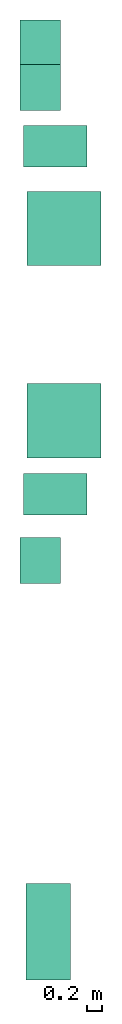
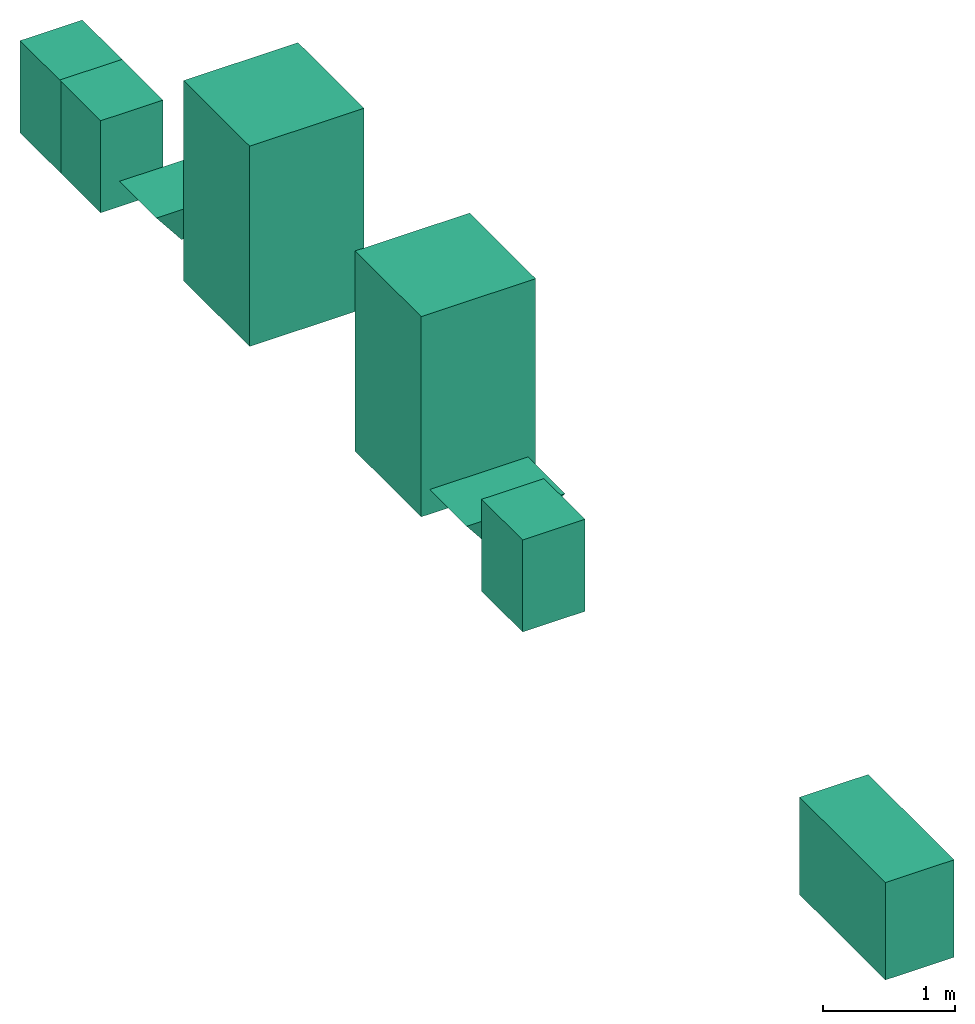
# One storey: 8 sanitary terminals.
"""IFC4 building model written with IfcOpenShell, lengths in millimetres."""

from ifc_helpers import new_model, entity, si_unit, converted_unit, frame, origin_with_axes, origin_2d_with_axis, place, context, subcontext, project, spatial, polygons, source, transform, mapped, type_object, type_shapes, element, save


model = new_model("IFC4")

# Units and contexts
model_context = context("Model", 3, precision=1e-05, world=origin_with_axes())
plan_context = context("Plan", 2, precision=1e-05, world=origin_2d_with_axis())
body_context = subcontext(model_context, "Body", "Model", "MODEL_VIEW")
ifc_project = project(units=[si_unit("VOLUMEUNIT", "CUBIC_METRE"), si_unit("LENGTHUNIT", "METRE", prefix="MILLI"), converted_unit("PLANEANGLEUNIT", "degree", entity("IfcReal", 0.0174532925199433), si_unit("PLANEANGLEUNIT", "RADIAN"), dimensions=[0, 0, 0, 0, 0, 0, 0]), si_unit("AREAUNIT", "SQUARE_METRE")], contexts=[model_context, plan_context])

# Site, building, storey
site_placement = place(None, origin_with_axes())
site = spatial("IfcSite", under=ifc_project, at=site_placement)
building_placement = place(site_placement, origin_with_axes())
building = spatial("IfcBuilding", under=site, at=building_placement, Name="Building")
storey_placement = place(building_placement, origin_with_axes())
storey = spatial("IfcBuildingStorey", under=building, at=storey_placement, Name="Plumbing")

# Sanitary terminals
sanitary_terminal_type_1 = type_object("IfcSanitaryTerminalType", Name="Shower", PredefinedType="SHOWER")
shared_shape_1 = source(origin_with_axes(), body_context, "Body", "Tessellation", [
    polygons([(0.0, 2.98023205687059e-05, 2.98023205687059e-05), (0.0, 999.999938964844, 2.98023205687059e-05), (0.0, 2.98023205687059e-05, 1849.99987792969), (0.0, 999.999938964844, 1849.99987792969), (999.999938964844, 999.999938964844, 2.98023205687059e-05), (999.999938964844, 999.999938964844, 1849.99987792969), (999.999938964844, 2.98023205687059e-05, 2.98023205687059e-05), (999.999938964844, 2.98023205687059e-05, 1849.99987792969)], [[[2, 4, 6, 5]], [[5, 6, 8, 7]], [[7, 1, 2, 5]], [[3, 8, 6, 4]], [[3, 1, 7, 8]], [[4, 2, 1, 3]]], closed=True),
])
type_shapes(sanitary_terminal_type_1, [shared_shape_1])
for number, where, z_axis, x_axis, name in (
    (1, (1622.69151210785, 12028.7218093872, 0.0), (0.0, 0.0, 1.0), (1.0, 0.0, 0.0), "SanitaryTerminal"),
    (2, (1622.69151210785, 14624.2475509644, 0.0), (0.0, 0.0, 1.0), (1.0, 0.0, 0.0), "SanitaryTerminal"),
):
    element("IfcSanitaryTerminal", number, at=place(storey_placement, frame(where, z_axis=z_axis, x_axis=x_axis)), inside=storey, type_object=sanitary_terminal_type_1, Name=name, context=body_context, shape_type="MappedRepresentation", body=[
        mapped(shared_shape_1, transform((0.0, 0.0, 0.0), x_axis=(1.0, 0.0, 0.0), y_axis=(0.0, 1.0, 0.0), z_axis=(0.0, 0.0, 1.0), scale=1.0)),
    ])
sanitary_terminal_type_2 = type_object("IfcSanitaryTerminalType", Name="Single basin", PredefinedType="WASHHANDBASIN")
shared_shape_2 = source(origin_with_axes(), body_context, "Body", "Tessellation", [
    polygons([(-499.999969482422, -499.999938964844, 2.98023205687059e-05), (-499.999969482422, 44.9999542236328, 2.98023205687059e-05), (-499.999969482422, -499.999938964844, 850.0), (-499.999969482422, 44.9999542236328, 850.0), (119.999938964844, 44.9999542236328, 2.98023205687059e-05), (119.999938964844, 44.9999542236328, 850.0), (119.999938964844, -499.999938964844, 2.98023205687059e-05), (119.999938964844, -499.999938964844, 850.0)], [[[2, 4, 6, 5]], [[5, 6, 8, 7]], [[7, 1, 2, 5]], [[3, 8, 6, 4]], [[3, 1, 7, 8]], [[4, 2, 1, 3]]], closed=True),
])
type_shapes(sanitary_terminal_type_2, [shared_shape_2])
for number, where, z_axis, x_axis, name in (
    (3, (1572.76248931885, 10830.4252624512, 0.0), (0.0, 0.0, 1.0), (7.54979012640431e-08, 0.999999999999997, 0.0), "SanitaryTerminal"),
    (4, (1572.76248931885, 17815.1626586914, 0.0), (0.0, 0.0, 1.0), (7.54979012640431e-08, 0.999999999999997, 0.0), "SanitaryTerminal"),
    (5, (1572.76248931885, 17215.1622772217, 0.0), (0.0, 0.0, 1.0), (7.54979012640431e-08, 0.999999999999997, 0.0), "SanitaryTerminal"),
):
    element("IfcSanitaryTerminal", number, at=place(storey_placement, frame(where, z_axis=z_axis, x_axis=x_axis)), inside=storey, type_object=sanitary_terminal_type_2, Name=name, context=body_context, shape_type="MappedRepresentation", body=[
        mapped(shared_shape_2, transform((0.0, 0.0, 0.0), x_axis=(1.0, 0.0, 0.0), y_axis=(0.0, 1.0, 0.0), z_axis=(0.0, 0.0, 1.0), scale=1.0)),
    ])
sanitary_terminal_type_3 = type_object("IfcSanitaryTerminalType", Name="Sink", PredefinedType="SINK")
shared_shape_3 = source(origin_with_axes(), body_context, "Body", "Tessellation", [
    polygons([(0.0, 0.0, 2.98023205687059e-05), (0.0, 1299.99987792969, 2.98023205687059e-05), (0.0, 0.0, 899.999938964844), (0.0, 1299.99987792969, 899.999938964844), (600.0, 1299.99987792969, 2.98023205687059e-05), (600.0, 1299.99987792969, 899.999938964844), (600.0, 0.0, 2.98023205687059e-05), (600.0, 0.0, 899.999938964844)], [[[2, 4, 6, 5]], [[5, 6, 8, 7]], [[7, 1, 2, 5]], [[3, 8, 6, 4]], [[3, 1, 7, 8]], [[4, 2, 1, 3]]], closed=True),
])
type_shapes(sanitary_terminal_type_3, [shared_shape_3])
sanitary_terminal_placement = place(storey_placement, frame((1610.2089881897, 4983.10518264771, 0.0), z_axis=(0.0, 0.0, 1.0), x_axis=(1.0, 0.0, 0.0)))
element("IfcSanitaryTerminal", 6, at=sanitary_terminal_placement, inside=storey, type_object=sanitary_terminal_type_3, Name="SanitaryTerminal", context=body_context, shape_type="MappedRepresentation", body=[
    mapped(shared_shape_3, transform((0.0, 0.0, 0.0), x_axis=(1.0, 0.0, 0.0), y_axis=(0.0, 1.0, 0.0), z_axis=(0.0, 0.0, 1.0), scale=1.0)),
])
sanitary_terminal_type_4 = type_object("IfcSanitaryTerminalType", Name="Toilet", PredefinedType="TOILETPAN")
shared_shape_4 = source(origin_with_axes(), body_context, "Body", "Tessellation", [
    polygons([(308.008087158203, 354.004028320312, 1.49011593748583e-05), (508.008026123047, 354.004028320312, -1.49011593748583e-05), (2.98023187497165e-05, 559.999938964844, 399.999938964844), (859.999938964844, 559.999938964844, 399.999938964844), (508.008026123047, 154.004028320312, -1.49011593748583e-05), (859.999938964844, 5.9604637499433e-05, 399.999938964844), (308.008087158203, 154.004028320312, 1.49011593748583e-05), (2.98023187497165e-05, 5.9604637499433e-05, 399.999938964844)], [[[6, 5, 2, 4]], [[8, 6, 4, 3]], [[5, 6, 8, 7]], [[5, 7, 1, 2]], [[3, 1, 7, 8]], [[1, 3, 4, 2]]], closed=True),
])
type_shapes(sanitary_terminal_type_4, [shared_shape_4])
for number, where, z_axis, x_axis, name in (
    (7, (1572.76248931885, 11254.8217773438, 0.0), (0.0, 0.0, 1.0), (1.0, 0.0, 0.0), "SanitaryTerminal"),
    (8, (1572.76248931885, 15949.0356445312, 0.0), (0.0, 0.0, 1.0), (1.0, 0.0, 0.0), "SanitaryTerminal"),
):
    element("IfcSanitaryTerminal", number, at=place(storey_placement, frame(where, z_axis=z_axis, x_axis=x_axis)), inside=storey, type_object=sanitary_terminal_type_4, Name=name, context=body_context, shape_type="MappedRepresentation", body=[
        mapped(shared_shape_4, transform((0.0, 0.0, 0.0), x_axis=(1.0, 0.0, 0.0), y_axis=(0.0, 1.0, 0.0), z_axis=(0.0, 0.0, 1.0), scale=1.0)),
    ])

save(model, "model.ifc")
